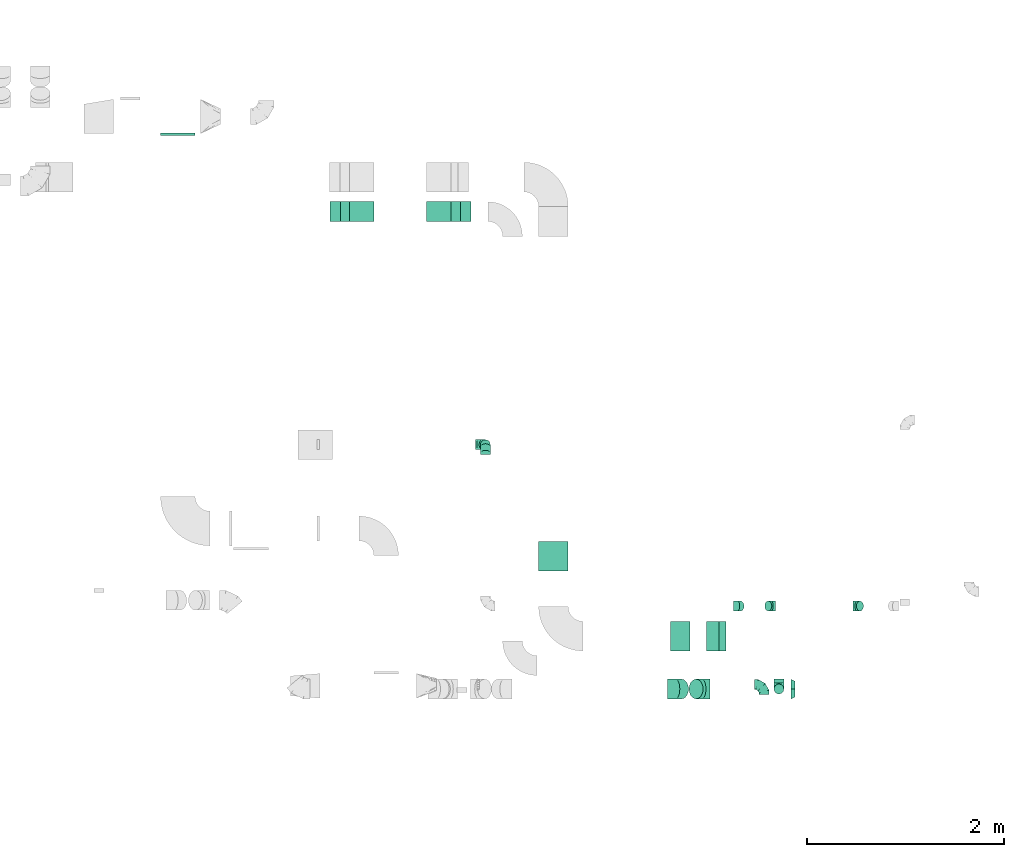
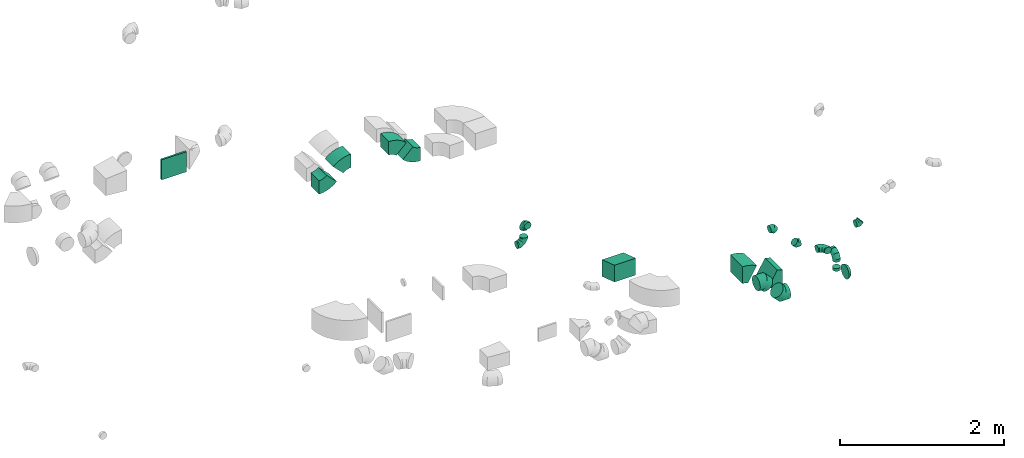
# One storey, part 30 of 44: 19 flow fittings.
"""IFC2X3 building model written with IfcOpenShell, lengths in millimetres."""

from ifc_helpers import new_model, entity, si_unit, converted_unit, derived_unit, direction, frame, frame_2d, origin, origin_2d_with_axis, place, context, subcontext, project, spatial, polyline, circle_curve, parameter, trimmed, segment, composite_curve, rectangle, outline, extrude, faceted_brep, source, transform, mapped, material, type_object, type_shapes, element, save


model = new_model("IFC2X3")

# Units and contexts
model_context = context("Model", 3, precision=0.01, world=origin(), true_north=direction((6.12303176911189e-17, 1.0)))
body_context = subcontext(model_context, "Body", "Model", "MODEL_VIEW")
ifc_project = project(units=[si_unit("LENGTHUNIT", "METRE", prefix="MILLI"), si_unit("AREAUNIT", "SQUARE_METRE"), si_unit("VOLUMEUNIT", "CUBIC_METRE"), converted_unit("PLANEANGLEUNIT", "DEGREE", entity("IfcRatioMeasure", 0.0174532925199433), si_unit("PLANEANGLEUNIT", "RADIAN"), dimensions=[0, 0, 0, 0, 0, 0, 0]), si_unit("MASSUNIT", "GRAM", prefix="KILO"), derived_unit("MASSDENSITYUNIT", [(si_unit("MASSUNIT", "GRAM", prefix="KILO"), 1), (si_unit("LENGTHUNIT", "METRE"), -3)]), derived_unit("MOMENTOFINERTIAUNIT", [(si_unit("LENGTHUNIT", "METRE"), 4)]), si_unit("TIMEUNIT", "SECOND"), si_unit("FREQUENCYUNIT", "HERTZ"), si_unit("THERMODYNAMICTEMPERATUREUNIT", "DEGREE_CELSIUS"), derived_unit("THERMALTRANSMITTANCEUNIT", [(si_unit("MASSUNIT", "GRAM", prefix="KILO"), 1), (si_unit("THERMODYNAMICTEMPERATUREUNIT", "KELVIN"), -1), (si_unit("TIMEUNIT", "SECOND"), -3)]), derived_unit("VOLUMETRICFLOWRATEUNIT", [(si_unit("LENGTHUNIT", "METRE"), 3), (si_unit("TIMEUNIT", "SECOND"), -1)]), derived_unit("MASSFLOWRATEUNIT", [(si_unit("MASSUNIT", "GRAM", prefix="KILO"), 1), (si_unit("TIMEUNIT", "SECOND"), -1)]), derived_unit("ROTATIONALFREQUENCYUNIT", [(si_unit("TIMEUNIT", "SECOND"), -1)]), si_unit("ELECTRICCURRENTUNIT", "AMPERE"), si_unit("ELECTRICVOLTAGEUNIT", "VOLT"), si_unit("POWERUNIT", "WATT"), si_unit("FORCEUNIT", "NEWTON", prefix="KILO"), si_unit("ILLUMINANCEUNIT", "LUX"), si_unit("LUMINOUSFLUXUNIT", "LUMEN"), si_unit("LUMINOUSINTENSITYUNIT", "CANDELA"), derived_unit("USERDEFINED", [(si_unit("MASSUNIT", "GRAM", prefix="KILO"), -1), (si_unit("LENGTHUNIT", "METRE"), -2), (si_unit("TIMEUNIT", "SECOND"), 3), (si_unit("LUMINOUSFLUXUNIT", "LUMEN"), 1)]), derived_unit("LINEARVELOCITYUNIT", [(si_unit("LENGTHUNIT", "METRE"), 1), (si_unit("TIMEUNIT", "SECOND"), -1)]), si_unit("PRESSUREUNIT", "PASCAL"), derived_unit("USERDEFINED", [(si_unit("LENGTHUNIT", "METRE"), -2), (si_unit("MASSUNIT", "GRAM", prefix="KILO"), 1), (si_unit("TIMEUNIT", "SECOND"), -2)]), derived_unit("LINEARFORCEUNIT", [(si_unit("MASSUNIT", "GRAM", prefix="KILO"), 1), (si_unit("LENGTHUNIT", "METRE"), 1), (si_unit("TIMEUNIT", "SECOND"), -2), (si_unit("LENGTHUNIT", "METRE"), -1)]), derived_unit("PLANARFORCEUNIT", [(si_unit("MASSUNIT", "GRAM", prefix="KILO"), 1), (si_unit("LENGTHUNIT", "METRE"), 1), (si_unit("TIMEUNIT", "SECOND"), -2), (si_unit("LENGTHUNIT", "METRE"), -2)])], contexts=[model_context])

# Site, building, storey
site_placement = place(None, origin())
site = spatial("IfcSite", under=ifc_project, at=site_placement, CompositionType="ELEMENT")
building_placement = place(site_placement, origin())
building = spatial("IfcBuilding", under=site, at=building_placement, CompositionType="ELEMENT")
storey_placement = place(building_placement, frame((0.0, 0.0, 15900.0)))
storey = spatial("IfcBuildingStorey", under=building, at=storey_placement, CompositionType="ELEMENT", Elevation=15900.0)

# Flow fittings
ifc_material = material()
duct_fitting_type_1 = type_object("IfcDuctFittingType", PredefinedType="NOTDEFINED", material=ifc_material)
shared_shape_1 = source(origin(), body_context, "Body", "SweptSolid", [
    extrude(rectangle(XDim=26.0960000000872, YDim=350.0, at=origin_2d_with_axis()), frame((6.95, 0.0, -150.0)), (0.0, 0.0, 1.0), 300.0),
])
type_shapes(duct_fitting_type_1, [shared_shape_1])
flow_fitting_1_placement = place(storey_placement, frame((58239.44, 14964.34, 3284.58), z_axis=(0.0, 0.0, -1.0), x_axis=(0.0, -1.0, 0.0)))
element("IfcFlowFitting", 1, at=flow_fitting_1_placement, inside=storey, type_object=duct_fitting_type_1, material=ifc_material, context=body_context, shape_type="MappedRepresentation", body=[
    mapped(shared_shape_1, transform((0.0, 0.0, 0.0), scale=1.0)),
])
duct_fitting_type_2 = type_object("IfcDuctFittingType", PredefinedType="NOTDEFINED", material=ifc_material)
shared_shape_2 = source(origin(), body_context, "Body", "SweptSolid", [
    extrude(outline(polyline([(-197.64, -118.59), (118.59, -118.59), (197.64, 118.59), (-118.59, 118.59), (-197.64, -118.59)])), frame((150.0, -150.0, -50.0), z_axis=(0.0, 1.0, 0.0), x_axis=(0.948683298050436, 0.0, -0.316227766017072)), (0.0, 0.0, 1.0), 300.0),
])
type_shapes(duct_fitting_type_2, [shared_shape_2])
flow_fitting_2_placement = place(storey_placement, frame((62044.65, 10534.23, 3075.0), z_axis=(0.0, 0.0, 1.0), x_axis=(0.0, 1.0, 0.0)))
element("IfcFlowFitting", 2, at=flow_fitting_2_placement, inside=storey, type_object=duct_fitting_type_2, material=ifc_material, context=body_context, shape_type="MappedRepresentation", body=[
    mapped(shared_shape_2, transform((0.0, 0.0, 0.0), scale=1.0)),
])
duct_fitting_type_3 = type_object("IfcDuctFittingType", PredefinedType="NOTDEFINED", material=ifc_material)
shared_shape_3 = source(origin(), body_context, "Body", "Brep", [
    faceted_brep([(-100.0, 0.0, -50.0), (-100.0, -12.94, -48.3), (-100.0, -25.0, -43.3), (-100.0, -35.36, -35.36), (-100.0, -43.3, -25.0), (-100.0, -48.3, -12.94), (-100.0, -50.0, 0.0), (-100.0, -48.3, 12.94), (-100.0, -43.3, 25.0), (-100.0, -35.36, 35.36), (-100.0, -25.0, 43.3), (-100.0, -12.94, 48.3), (-100.0, 0.0, 50.0), (-100.0, 12.94, 48.3), (-100.0, 25.0, 43.3), (-100.0, 35.36, 35.36), (-100.0, 43.3, 25.0), (-100.0, 48.3, 12.94), (-100.0, 50.0, 0.0), (-100.0, 48.3, -12.94), (-100.0, 43.3, -25.0), (-100.0, 35.36, -35.36), (-100.0, 25.0, -43.3), (-100.0, 12.94, -48.3), (-76.67, 12.94, 48.3), (-79.9, 25.0, 43.3), (-73.21, 0.0, 50.0), (-82.68, 35.36, 35.36), (-86.15, 48.3, 12.94), (-86.6, 50.0, 0.0), (-84.81, 43.3, 25.0), (-84.81, 43.3, -25.0), (-82.68, 35.36, -35.36), (-86.15, 48.3, -12.94), (-76.67, 12.94, -48.3), (-73.21, 0.0, -50.0), (-79.9, 25.0, -43.3), (-69.74, -12.94, -48.3), (-66.51, -25.0, -43.3), (-63.73, -35.36, -35.36), (-61.6, -43.3, -25.0), (-60.26, -48.3, -12.94), (-59.81, -50.0, 0.0), (-60.26, -48.3, 12.94), (-61.6, -43.3, 25.0), (-63.73, -35.36, 35.36), (-66.51, -25.0, 43.3), (-69.74, -12.94, 48.3), (-36.27, 36.27, 48.3), (-45.1, 45.1, 43.3), (-26.79, 26.79, 50.0), (-52.68, 52.68, 35.36), (-58.49, 58.49, 25.0), (-62.15, 62.15, 12.94), (-63.4, 63.4, 0.0), (-62.15, 62.15, -12.94), (-58.49, 58.49, -25.0), (-52.68, 52.68, -35.36), (-36.27, 36.27, -48.3), (-26.79, 26.79, -50.0), (-45.1, 45.1, -43.3), (-17.32, 17.32, -48.3), (-8.49, 8.49, -43.3), (-0.91, 0.91, -35.36), (4.9, -4.9, -25.0), (8.56, -8.56, -12.94), (9.81, -9.81, 0.0), (8.56, -8.56, 12.94), (4.9, -4.9, 25.0), (-0.91, 0.91, 35.36), (-8.49, 8.49, 43.3), (-17.32, 17.32, 48.3), (-12.94, 76.67, 48.3), (-25.0, 79.9, 43.3), (0.0, 73.21, 50.0), (-35.36, 82.68, 35.36), (-43.3, 84.81, 25.0), (-48.3, 86.15, 12.94), (-50.0, 86.6, 0.0), (-48.3, 86.15, -12.94), (-43.3, 84.81, -25.0), (-35.36, 82.68, -35.36), (-12.94, 76.67, -48.3), (0.0, 73.21, -50.0), (-25.0, 79.9, -43.3), (12.94, 69.74, -48.3), (25.0, 66.51, -43.3), (35.36, 63.73, -35.36), (43.3, 61.6, -25.0), (48.3, 60.26, -12.94), (50.0, 59.81, 0.0), (48.3, 60.26, 12.94), (43.3, 61.6, 25.0), (35.36, 63.73, 35.36), (25.0, 66.51, 43.3), (12.94, 69.74, 48.3), (-12.94, 100.0, -48.3), (-25.0, 100.0, -43.3), (-35.36, 100.0, -35.36), (-43.3, 100.0, -25.0), (-48.3, 100.0, -12.94), (-50.0, 100.0, 0.0), (-48.3, 100.0, 12.94), (-43.3, 100.0, 25.0), (-35.36, 100.0, 35.36), (-25.0, 100.0, 43.3), (-12.94, 100.0, 48.3), (0.0, 100.0, 50.0), (12.94, 100.0, 48.3), (25.0, 100.0, 43.3), (35.36, 100.0, 35.36), (43.3, 100.0, 25.0), (48.3, 100.0, 12.94), (50.0, 100.0, 0.0), (48.3, 100.0, -12.94), (43.3, 100.0, -25.0), (35.36, 100.0, -35.36), (25.0, 100.0, -43.3), (12.94, 100.0, -48.3), (0.0, 100.0, -50.0)], [[[0, 1, 2, 3, 4, 5, 6, 7, 8, 9, 10, 11, 12, 13, 14, 15, 16, 17, 18, 19, 20, 21, 22, 23]], [[24, 25, 14, 13]], [[26, 24, 13, 12]], [[14, 25, 27, 15]], [[28, 29, 18, 17]], [[30, 28, 17, 16]], [[15, 27, 30, 16]], [[20, 31, 32, 21]], [[33, 31, 20, 19]], [[18, 29, 33, 19]], [[34, 35, 0, 23]], [[36, 34, 23, 22]], [[32, 36, 22, 21]], [[2, 1, 37, 38]], [[3, 2, 38, 39]], [[0, 35, 37, 1]], [[5, 4, 40, 41]], [[6, 5, 41, 42]], [[3, 39, 40, 4]], [[6, 42, 43, 7]], [[7, 43, 44, 8]], [[8, 44, 45, 9]], [[10, 46, 47, 11]], [[11, 47, 26, 12]], [[10, 9, 45, 46]], [[48, 49, 25, 24]], [[50, 48, 24, 26]], [[27, 25, 49, 51]], [[52, 53, 28, 30]], [[51, 52, 30, 27]], [[29, 28, 53, 54]], [[55, 56, 31, 33]], [[54, 55, 33, 29]], [[57, 32, 31, 56]], [[58, 59, 35, 34]], [[60, 58, 34, 36]], [[57, 60, 36, 32]], [[37, 35, 59, 61]], [[38, 37, 61, 62]], [[39, 38, 62, 63]], [[41, 40, 64, 65]], [[42, 41, 65, 66]], [[63, 64, 40, 39]], [[43, 42, 66, 67]], [[44, 43, 67, 68]], [[68, 69, 45, 44]], [[46, 45, 69, 70]], [[47, 46, 70, 71]], [[26, 47, 71, 50]], [[72, 73, 49, 48]], [[74, 72, 48, 50]], [[51, 49, 73, 75]], [[76, 77, 53, 52]], [[75, 76, 52, 51]], [[54, 53, 77, 78]], [[79, 80, 56, 55]], [[78, 79, 55, 54]], [[81, 57, 56, 80]], [[82, 83, 59, 58]], [[84, 82, 58, 60]], [[81, 84, 60, 57]], [[61, 59, 83, 85]], [[62, 61, 85, 86]], [[63, 62, 86, 87]], [[65, 64, 88, 89]], [[66, 65, 89, 90]], [[87, 88, 64, 63]], [[67, 66, 90, 91]], [[68, 67, 91, 92]], [[92, 93, 69, 68]], [[70, 69, 93, 94]], [[71, 70, 94, 95]], [[50, 71, 95, 74]], [[96, 97, 98, 99, 100, 101, 102, 103, 104, 105, 106, 107, 108, 109, 110, 111, 112, 113, 114, 115, 116, 117, 118, 119]], [[72, 74, 107, 106]], [[73, 72, 106, 105]], [[75, 73, 105, 104]], [[77, 76, 103, 102]], [[78, 77, 102, 101]], [[75, 104, 103, 76]], [[78, 101, 100, 79]], [[79, 100, 99, 80]], [[80, 99, 98, 81]], [[96, 119, 83, 82]], [[97, 96, 82, 84]], [[84, 81, 98, 97]], [[83, 119, 118, 85]], [[85, 118, 117, 86]], [[86, 117, 116, 87]], [[88, 115, 114, 89]], [[89, 114, 113, 90]], [[87, 116, 115, 88]], [[91, 90, 113, 112]], [[92, 91, 112, 111]], [[93, 92, 111, 110]], [[95, 94, 109, 108]], [[74, 95, 108, 107]], [[110, 109, 94, 93]]]),
])
type_shapes(duct_fitting_type_3, [shared_shape_3])
for number, where, z_axis, x_axis in (
    (3, (64329.32, 9338.57, 3250.0), (-1.0, 0.0, 0.0), (0.0, 0.0, 1.0)),
    (4, (61355.06, 11814.05, 2950.0), (0.0, -1.0, 0.0), (1.0, 0.0, 0.0)),
    (5, (61355.06, 11814.05, 3260.0), (1.0, 0.0, 0.0), (0.0, 0.0, 1.0)),
    (6, (64179.84, 9385.12, 3375.0), (0.0, 0.0, 1.0), (0.0, 1.0, 0.0)),
):
    element("IfcFlowFitting", number, at=place(storey_placement, frame(where, z_axis=z_axis, x_axis=x_axis)), inside=storey, type_object=duct_fitting_type_3, material=ifc_material, context=body_context, shape_type="MappedRepresentation", body=[
        mapped(shared_shape_3, transform((0.0, 0.0, 0.0), scale=1.0)),
    ])
duct_fitting_type_4 = type_object("IfcDuctFittingType", PredefinedType="NOTDEFINED", material=ifc_material)
shared_shape_4 = source(origin(), body_context, "Body", "Brep", [
    faceted_brep([(-41.42, 0.0, -50.0), (-41.42, -12.94, -48.3), (-41.42, -25.0, -43.3), (-41.42, -35.36, -35.36), (-41.42, -43.3, -25.0), (-41.42, -48.3, -12.94), (-41.42, -50.0, 0.0), (-41.42, -48.3, 12.94), (-41.42, -43.3, 25.0), (-41.42, -35.36, 35.36), (-41.42, -25.0, 43.3), (-41.42, -12.94, 48.3), (-41.42, 0.0, 50.0), (-41.42, 12.94, 48.3), (-41.42, 25.0, 43.3), (-41.42, 35.36, 35.36), (-41.42, 43.3, 25.0), (-41.42, 48.3, 12.94), (-41.42, 50.0, 0.0), (-41.42, 48.3, -12.94), (-41.42, 43.3, -25.0), (-41.42, 35.36, -35.36), (-41.42, 25.0, -43.3), (-41.42, 12.94, -48.3), (-5.36, 12.94, 48.3), (-10.36, 25.0, 43.3), (0.0, 0.0, 50.0), (-14.64, 35.36, 35.36), (-20.0, 48.3, 12.94), (-20.71, 50.0, 0.0), (-17.94, 43.3, 25.0), (-17.94, 43.3, -25.0), (-14.64, 35.36, -35.36), (-20.0, 48.3, -12.94), (-5.36, 12.94, -48.3), (0.0, 0.0, -50.0), (-10.36, 25.0, -43.3), (5.36, -12.94, -48.3), (10.36, -25.0, -43.3), (14.64, -35.36, -35.36), (17.94, -43.3, -25.0), (20.0, -48.3, -12.94), (20.71, -50.0, 0.0), (20.0, -48.3, 12.94), (17.94, -43.3, 25.0), (14.64, -35.36, 35.36), (10.36, -25.0, 43.3), (5.36, -12.94, 48.3), (29.29, 29.29, 50.0), (20.14, 38.44, 48.3), (11.61, 46.97, 43.3), (4.29, 54.29, 35.36), (-1.33, 59.91, 25.0), (-4.86, 63.44, 12.94), (-6.07, 64.64, 0.0), (-4.86, 63.44, -12.94), (-1.33, 59.91, -25.0), (4.29, 54.29, -35.36), (11.61, 46.97, -43.3), (20.14, 38.44, -48.3), (29.29, 29.29, -50.0), (38.44, 20.14, -48.3), (46.97, 11.61, -43.3), (54.29, 4.29, -35.36), (59.91, -1.33, -25.0), (63.44, -4.86, -12.94), (64.64, -6.07, 0.0), (63.44, -4.86, 12.94), (59.91, -1.33, 25.0), (54.29, 4.29, 35.36), (46.97, 11.61, 43.3), (38.44, 20.14, 48.3)], [[[0, 1, 2, 3, 4, 5, 6, 7, 8, 9, 10, 11, 12, 13, 14, 15, 16, 17, 18, 19, 20, 21, 22, 23]], [[24, 25, 14, 13]], [[26, 24, 13, 12]], [[14, 25, 27, 15]], [[28, 29, 18, 17]], [[30, 28, 17, 16]], [[16, 15, 27, 30]], [[20, 31, 32, 21]], [[33, 31, 20, 19]], [[18, 29, 33, 19]], [[34, 35, 0, 23]], [[36, 34, 23, 22]], [[32, 36, 22, 21]], [[1, 0, 35, 37]], [[2, 1, 37, 38]], [[38, 39, 3, 2]], [[5, 4, 40, 41]], [[6, 5, 41, 42]], [[39, 40, 4, 3]], [[6, 42, 43, 7]], [[7, 43, 44, 8]], [[8, 44, 45, 9]], [[9, 45, 46, 10]], [[10, 46, 47, 11]], [[26, 12, 11, 47]], [[24, 26, 48, 49]], [[25, 24, 49, 50]], [[27, 25, 50, 51]], [[28, 30, 52, 53]], [[29, 28, 53, 54]], [[27, 51, 52, 30]], [[29, 54, 55, 33]], [[33, 55, 56, 31]], [[31, 56, 57, 32]], [[36, 58, 59, 34]], [[34, 59, 60, 35]], [[36, 32, 57, 58]], [[61, 62, 38, 37]], [[60, 61, 37, 35]], [[63, 39, 38, 62]], [[40, 64, 65, 41]], [[41, 65, 66, 42]], [[64, 40, 39, 63]], [[43, 42, 66, 67]], [[44, 43, 67, 68]], [[68, 69, 45, 44]], [[47, 46, 70, 71]], [[26, 47, 71, 48]], [[69, 70, 46, 45]], [[59, 58, 57, 56, 55, 54, 53, 52, 51, 50, 49, 48, 71, 70, 69, 68, 67, 66, 65, 64, 63, 62, 61, 60]]]),
])
type_shapes(duct_fitting_type_4, [shared_shape_4])
for number, where, z_axis, x_axis in (
    (7, (64251.06, 10179.05, 2920.0), (0.0, 1.0, 0.0), (-1.0, 0.0, 0.0)),
    (8, (63911.06, 10179.05, 3260.0), (0.0, -1.0, 0.0), (-0.707106781186509, 0.0, 0.707106781186586)),
    (9, (65121.06, 10179.05, 2920.0), (0.0, -1.0, 0.0), (1.0, 0.0, 0.0)),
):
    element("IfcFlowFitting", number, at=place(storey_placement, frame(where, z_axis=z_axis, x_axis=x_axis)), inside=storey, type_object=duct_fitting_type_4, material=ifc_material, context=body_context, shape_type="MappedRepresentation", body=[
        mapped(shared_shape_4, transform((0.0, 0.0, 0.0), scale=1.0)),
    ])
duct_fitting_type_5 = type_object("IfcDuctFittingType", PredefinedType="NOTDEFINED", material=ifc_material)
shared_shape_5 = source(origin(), body_context, "Body", "Brep", [
    faceted_brep([(-82.84, 0.0, -100.0), (-82.84, -25.88, -96.59), (-82.84, -50.0, -86.6), (-82.84, -70.71, -70.71), (-82.84, -86.6, -50.0), (-82.84, -96.59, -25.88), (-82.84, -100.0, 0.0), (-82.84, -96.59, 25.88), (-82.84, -86.6, 50.0), (-82.84, -70.71, 70.71), (-82.84, -50.0, 86.6), (-82.84, -25.88, 96.59), (-82.84, 0.0, 100.0), (-82.84, 25.88, 96.59), (-82.84, 50.0, 86.6), (-82.84, 70.71, 70.71), (-82.84, 86.6, 50.0), (-82.84, 96.59, 25.88), (-82.84, 100.0, 0.0), (-82.84, 96.59, -25.88), (-82.84, 86.6, -50.0), (-82.84, 70.71, -70.71), (-82.84, 50.0, -86.6), (-82.84, 25.88, -96.59), (-10.72, 25.88, 96.59), (-20.71, 50.0, 86.6), (0.0, 0.0, 100.0), (-29.29, 70.71, 70.71), (-35.87, 86.6, 50.0), (-40.01, 96.59, 25.88), (-41.42, 100.0, 0.0), (-40.01, 96.59, -25.88), (-35.87, 86.6, -50.0), (-29.29, 70.71, -70.71), (-10.72, 25.88, -96.59), (0.0, 0.0, -100.0), (-20.71, 50.0, -86.6), (10.72, -25.88, -96.59), (20.71, -50.0, -86.6), (29.29, -70.71, -70.71), (35.87, -86.6, -50.0), (40.01, -96.59, -25.88), (41.42, -100.0, 0.0), (40.01, -96.59, 25.88), (35.87, -86.6, 50.0), (29.29, -70.71, 70.71), (20.71, -50.0, 86.6), (10.72, -25.88, 96.59), (58.58, 58.58, 100.0), (40.28, 76.88, 96.59), (23.22, 93.93, 86.6), (8.58, 108.58, 70.71), (-2.66, 119.82, 50.0), (-9.72, 126.88, 25.88), (-12.13, 129.29, 0.0), (-9.72, 126.88, -25.88), (-2.66, 119.82, -50.0), (8.58, 108.58, -70.71), (23.22, 93.93, -86.6), (40.28, 76.88, -96.59), (58.58, 58.58, -100.0), (76.88, 40.28, -96.59), (93.93, 23.22, -86.6), (108.58, 8.58, -70.71), (119.82, -2.66, -50.0), (126.88, -9.72, -25.88), (129.29, -12.13, 0.0), (126.88, -9.72, 25.88), (119.82, -2.66, 50.0), (108.58, 8.58, 70.71), (93.93, 23.22, 86.6), (76.88, 40.28, 96.59)], [[[0, 1, 2, 3, 4, 5, 6, 7, 8, 9, 10, 11, 12, 13, 14, 15, 16, 17, 18, 19, 20, 21, 22, 23]], [[24, 25, 14, 13]], [[26, 24, 13, 12]], [[14, 25, 27, 15]], [[28, 29, 17, 16]], [[28, 16, 15, 27]], [[30, 18, 17, 29]], [[31, 32, 20, 19]], [[30, 31, 19, 18]], [[32, 33, 21, 20]], [[34, 35, 0, 23]], [[36, 34, 23, 22]], [[33, 36, 22, 21]], [[1, 0, 35, 37]], [[2, 1, 37, 38]], [[38, 39, 3, 2]], [[5, 4, 40, 41]], [[6, 5, 41, 42]], [[39, 40, 4, 3]], [[6, 42, 43, 7]], [[7, 43, 44, 8]], [[8, 44, 45, 9]], [[9, 45, 46, 10]], [[10, 46, 47, 11]], [[26, 12, 11, 47]], [[24, 26, 48, 49]], [[25, 24, 49, 50]], [[27, 25, 50, 51]], [[29, 28, 52, 53]], [[30, 29, 53, 54]], [[51, 52, 28, 27]], [[30, 54, 55, 31]], [[31, 55, 56, 32]], [[57, 33, 32, 56]], [[36, 58, 59, 34]], [[34, 59, 60, 35]], [[58, 36, 33, 57]], [[35, 60, 61, 37]], [[37, 61, 62, 38]], [[63, 39, 38, 62]], [[40, 64, 65, 41]], [[41, 65, 66, 42]], [[64, 40, 39, 63]], [[43, 42, 66, 67]], [[44, 43, 67, 68]], [[68, 69, 45, 44]], [[47, 46, 70, 71]], [[26, 47, 71, 48]], [[69, 70, 46, 45]], [[59, 58, 57, 56, 55, 54, 53, 52, 51, 50, 49, 48, 71, 70, 69, 68, 67, 66, 65, 64, 63, 62, 61, 60]]]),
])
type_shapes(duct_fitting_type_5, [shared_shape_5])
for number, where, z_axis, x_axis in (
    (10, (63283.71, 9338.57, 3200.0), (0.0, 1.0, 0.0), (1.0, 0.0, 0.0)),
    (11, (63548.71, 9338.57, 2935.0), (0.0, 1.0, 0.0), (-1.0, 0.0, 0.0)),
):
    element("IfcFlowFitting", number, at=place(storey_placement, frame(where, z_axis=z_axis, x_axis=x_axis)), inside=storey, type_object=duct_fitting_type_5, material=ifc_material, context=body_context, shape_type="MappedRepresentation", body=[
        mapped(shared_shape_5, transform((0.0, 0.0, 0.0), scale=1.0)),
    ])
duct_fitting_type_6 = type_object("IfcDuctFittingType", PredefinedType="NOTDEFINED", material=ifc_material)
shared_shape_6 = source(origin(), body_context, "Body", "Brep", [
    faceted_brep([(40.0, -73.91, 30.61), (40.0, -76.96, 15.31), (40.0, -80.0, 0.0), (40.0, -76.96, -15.31), (40.0, -73.91, -30.61), (40.0, -65.24, -43.59), (40.0, -56.57, -56.57), (40.0, -43.59, -65.24), (40.0, -30.61, -73.91), (40.0, -15.31, -76.96), (40.0, 0.0, -80.0), (40.0, 15.31, -76.96), (40.0, 30.61, -73.91), (40.0, 43.59, -65.24), (40.0, 56.57, -56.57), (40.0, 65.24, -43.59), (40.0, 73.91, -30.61), (40.0, 76.96, -15.31), (40.0, 80.0, 0.0), (40.0, 76.96, 15.31), (40.0, 73.91, 30.61), (40.0, 65.24, 43.59), (40.0, 56.57, 56.57), (40.0, 43.59, 65.24), (40.0, 30.61, 73.91), (40.0, 15.31, 76.96), (40.0, 0.0, 80.0), (40.0, -15.31, 76.96), (40.0, -30.61, 73.91), (40.0, -43.59, 65.24), (40.0, -56.57, 56.57), (40.0, -65.24, 43.59), (0.0, -100.0, 0.0), (0.0, -95.11, 30.9), (0.0, -80.9, 58.78), (0.0, -58.78, 80.9), (0.0, -30.9, 95.11), (0.0, 0.0, 100.0), (0.0, 30.9, 95.11), (0.0, 58.78, 80.9), (0.0, 80.9, 58.78), (0.0, 95.11, 30.9), (0.0, 100.0, 0.0), (0.0, 95.11, -30.9), (0.0, 80.9, -58.78), (0.0, 58.78, -80.9), (0.0, 30.9, -95.11), (0.0, 0.0, -100.0), (0.0, -30.9, -95.11), (0.0, -58.78, -80.9), (0.0, -80.9, -58.78), (0.0, -95.11, -30.9)], [[[0, 1, 2, 3, 4, 5, 6, 7, 8, 9, 10, 11, 12, 13, 14, 15, 16, 17, 18, 19, 20, 21, 22, 23, 24, 25, 26, 27, 28, 29, 30, 31]], [[32, 33, 34, 35, 36, 37, 38, 39, 40, 41, 42, 43, 44, 45, 46, 47, 48, 49, 50, 51]], [[37, 25, 38]], [[25, 24, 38]], [[24, 39, 38]], [[41, 20, 19]], [[25, 37, 26]], [[39, 24, 23, 22]], [[42, 19, 18]], [[20, 40, 22, 21]], [[41, 40, 20]], [[42, 41, 19]], [[22, 40, 39]], [[32, 1, 33]], [[1, 0, 33]], [[0, 34, 33]], [[36, 28, 27]], [[1, 32, 2]], [[34, 0, 31, 30]], [[37, 27, 26]], [[28, 35, 30, 29]], [[36, 35, 28]], [[37, 36, 27]], [[30, 35, 34]], [[47, 9, 48]], [[9, 8, 48]], [[8, 49, 48]], [[51, 4, 3]], [[9, 47, 10]], [[49, 8, 7, 6]], [[32, 3, 2]], [[4, 50, 6, 5]], [[51, 50, 4]], [[32, 51, 3]], [[6, 50, 49]], [[42, 17, 43]], [[17, 16, 43]], [[16, 44, 43]], [[46, 12, 11]], [[17, 42, 18]], [[44, 16, 15, 14]], [[47, 11, 10]], [[12, 45, 14, 13]], [[46, 45, 12]], [[47, 46, 11]], [[14, 45, 44]]]),
])
type_shapes(duct_fitting_type_6, [shared_shape_6])
flow_fitting_3_placement = place(storey_placement, frame((64451.97, 9338.57, 2935.0)))
element("IfcFlowFitting", 12, at=flow_fitting_3_placement, inside=storey, type_object=duct_fitting_type_6, material=ifc_material, context=body_context, shape_type="MappedRepresentation", body=[
    mapped(shared_shape_6, transform((0.0, 0.0, 0.0), scale=1.0)),
])
duct_fitting_type_7 = type_object("IfcDuctFittingType", PredefinedType="NOTDEFINED", material=ifc_material)
shared_shape_7 = source(origin(), body_context, "Body", "Brep", [
    faceted_brep([(20.0, 12.94, -48.3), (20.0, 25.0, -43.3), (20.0, 35.36, -35.36), (20.0, 43.3, -25.0), (20.0, 48.3, -12.94), (20.0, 50.0, 0.0), (20.0, 48.3, 12.94), (20.0, 43.3, 25.0), (20.0, 35.36, 35.36), (20.0, 25.0, 43.3), (20.0, 12.94, 48.3), (20.0, 0.0, 50.0), (20.0, -12.94, 48.3), (20.0, -25.0, 43.3), (20.0, -35.36, 35.36), (20.0, -43.3, 25.0), (20.0, -48.3, 12.94), (20.0, -50.0, 0.0), (20.0, -48.3, -12.94), (20.0, -43.3, -25.0), (20.0, -35.36, -35.36), (20.0, -25.0, -43.3), (20.0, -12.94, -48.3), (20.0, 0.0, -50.0), (0.0, 0.0, 50.0), (0.0, 12.94, 48.3), (-19.49, 12.94, 48.3), (-19.49, 0.0, 50.0), (0.0, 25.0, 43.3), (-19.49, 25.0, 43.3), (0.0, 35.36, 35.36), (-19.49, 35.36, 35.36), (0.0, 43.3, 25.0), (0.0, 48.3, 12.94), (-19.49, 48.3, 12.94), (-19.49, 43.3, 25.0), (0.0, 50.0, 0.0), (-19.49, 50.0, 0.0), (0.0, 48.3, -12.94), (-19.49, 48.3, -12.94), (0.0, 43.3, -25.0), (-19.49, 43.3, -25.0), (0.0, 35.36, -35.36), (-19.49, 35.36, -35.36), (0.0, 25.0, -43.3), (0.0, 12.94, -48.3), (-19.49, 12.94, -48.3), (-19.49, 25.0, -43.3), (0.0, 0.0, -50.0), (-19.49, 0.0, -50.0), (0.0, -12.94, -48.3), (-19.49, -12.94, -48.3), (0.0, -25.0, -43.3), (-19.49, -25.0, -43.3), (0.0, -35.36, -35.36), (-19.49, -35.36, -35.36), (0.0, -43.3, -25.0), (0.0, -48.3, -12.94), (-19.49, -48.3, -12.94), (-19.49, -43.3, -25.0), (0.0, -50.0, 0.0), (-19.49, -50.0, 0.0), (0.0, -48.3, 12.94), (-19.49, -48.3, 12.94), (0.0, -43.3, 25.0), (-19.49, -43.3, 25.0), (0.0, -35.36, 35.36), (-19.49, -35.36, 35.36), (0.0, -25.0, 43.3), (0.0, -12.94, 48.3), (-19.49, -12.94, 48.3), (-19.49, -25.0, 43.3)], [[[0, 1, 2, 3, 4, 5, 6, 7, 8, 9, 10, 11, 12, 13, 14, 15, 16, 17, 18, 19, 20, 21, 22, 23]], [[24, 11, 10, 25, 26, 27]], [[25, 10, 9, 28, 29, 26]], [[28, 9, 8, 30, 31, 29]], [[32, 7, 6, 33, 34, 35]], [[33, 6, 5, 36, 37, 34]], [[30, 8, 7, 32, 35, 31]], [[36, 5, 4, 38, 39, 37]], [[38, 4, 3, 40, 41, 39]], [[40, 3, 2, 42, 43, 41]], [[44, 1, 0, 45, 46, 47]], [[45, 0, 23, 48, 49, 46]], [[42, 2, 1, 44, 47, 43]], [[48, 23, 22, 50, 51, 49]], [[50, 22, 21, 52, 53, 51]], [[52, 21, 20, 54, 55, 53]], [[56, 19, 18, 57, 58, 59]], [[57, 18, 17, 60, 61, 58]], [[54, 20, 19, 56, 59, 55]], [[60, 17, 16, 62, 63, 61]], [[62, 16, 15, 64, 65, 63]], [[64, 15, 14, 66, 67, 65]], [[68, 13, 12, 69, 70, 71]], [[69, 12, 11, 24, 27, 70]], [[66, 14, 13, 68, 71, 67]], [[49, 51, 53, 55, 59, 58, 61, 63, 65, 67, 71, 70, 27, 26, 29, 31, 35, 34, 37, 39, 41, 43, 47, 46]]]),
])
type_shapes(duct_fitting_type_7, [shared_shape_7])
flow_fitting_4_placement = place(storey_placement, frame((64329.32, 9338.57, 3035.0), z_axis=(0.0, -1.0, 0.0), x_axis=(0.0, 0.0, 1.0)))
element("IfcFlowFitting", 13, at=flow_fitting_4_placement, inside=storey, type_object=duct_fitting_type_7, material=ifc_material, context=body_context, shape_type="MappedRepresentation", body=[
    mapped(shared_shape_7, transform((0.0, 0.0, 0.0), scale=1.0)),
])
duct_fitting_type_8 = type_object("IfcDuctFittingType", PredefinedType="NOTDEFINED", material=ifc_material)
shared_shape_8 = source(origin(), body_context, "Body", "SweptSolid", [
    extrude(outline(composite_curve([segment(polyline([(-136.61, -88.39), (63.39, -88.39)]), True, "CONTINUOUS"), segment(trimmed(circle_curve(frame_2d((213.39, -88.39), x_axis=(-0.707106781186546, 0.707106781186546)), 150.0), [parameter(0.0)], [parameter(45.0)], True, "PARAMETER"), False, "CONTINUOUS"), segment(polyline([(107.32, 17.68), (-34.1, 159.1)]), True, "CONTINUOUS"), segment(trimmed(circle_curve(frame_2d((213.39, -88.39), x_axis=(-0.707106781186546, 0.707106781186546)), 350.0), [parameter(0.0)], [parameter(45.0)], True, "PARAMETER"), True, "CONTINUOUS")], self_intersect=False)), frame((-15.17, 36.61, -100.0), z_axis=(0.0, 0.0, 1.0), x_axis=(-0.707106781186547, 0.707106781186548, 0.0)), (0.0, 0.0, 1.0), 200.0),
])
type_shapes(duct_fitting_type_8, [shared_shape_8])
for number, where, z_axis, x_axis in (
    (14, (59883.63, 14175.53, 2950.0), (0.0, -1.0, 0.0), (1.0, 0.0, 0.0)),
    (15, (60124.05, 14175.53, 3190.42), (0.0, 1.0, 0.0), (0.707106781186511, 0.0, 0.707106781186584)),
    (16, (60864.05, 14175.53, 3190.42), (0.0, 1.0, 0.0), (1.0, 0.0, 0.0)),
    (17, (61104.47, 14175.53, 2950.0), (0.0, -1.0, 0.0), (0.70710678118645, 0.0, -0.707106781186645)),
):
    element("IfcFlowFitting", number, at=place(storey_placement, frame(where, z_axis=z_axis, x_axis=x_axis)), inside=storey, type_object=duct_fitting_type_8, material=ifc_material, context=body_context, shape_type="MappedRepresentation", body=[
        mapped(shared_shape_8, transform((0.0, 0.0, 0.0), scale=1.0)),
    ])
duct_fitting_type_9 = type_object("IfcDuctFittingType", PredefinedType="NOTDEFINED", material=ifc_material)
shared_shape_9 = source(origin(), body_context, "Body", "SweptSolid", [
    extrude(outline(composite_curve([segment(polyline([(-143.34, -68.61), (106.66, -68.61)]), True, "CONTINUOUS"), segment(trimmed(circle_curve(frame_2d((256.66, -68.61), x_axis=(-0.866592612867304, 0.499016275610144)), 150.0), [parameter(0.0)], [parameter(29.9349386314298)], True, "PARAMETER"), False, "CONTINUOUS"), segment(polyline([(126.67, 6.24), (-89.98, 130.99)]), True, "CONTINUOUS"), segment(trimmed(circle_curve(frame_2d((256.66, -68.61), x_axis=(-0.866592612867304, 0.499016275610144)), 400.0), [parameter(0.0)], [parameter(29.9349386314298)], True, "PARAMETER"), True, "CONTINUOUS")], self_intersect=False)), frame((-4.9, 18.34, -150.0), z_axis=(0.0, 0.0, 1.0), x_axis=(-0.499016275610144, 0.866592612867304, 0.0)), (0.0, 0.0, 1.0), 300.0),
])
type_shapes(duct_fitting_type_9, [shared_shape_9])
for number, where, z_axis, x_axis in (
    (18, (63721.48, 9874.07, 2835.0), (0.0, 1.0, 0.0), (-1.0, 0.0, 0.0)),
    (19, (63304.7, 9874.07, 3075.0), (0.0, 1.0, 0.0), (1.0, 0.0, 0.0)),
):
    element("IfcFlowFitting", number, at=place(storey_placement, frame(where, z_axis=z_axis, x_axis=x_axis)), inside=storey, type_object=duct_fitting_type_9, material=ifc_material, context=body_context, shape_type="MappedRepresentation", body=[
        mapped(shared_shape_9, transform((0.0, 0.0, 0.0), scale=1.0)),
    ])

save(model, "model.ifc")
